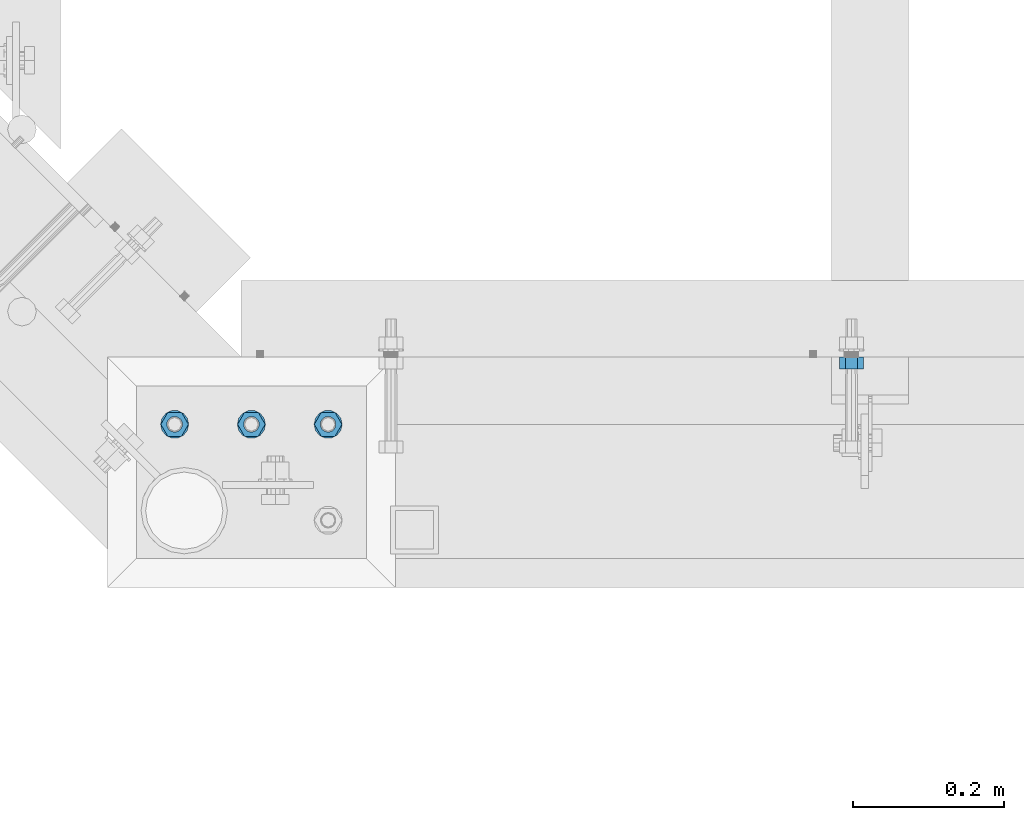
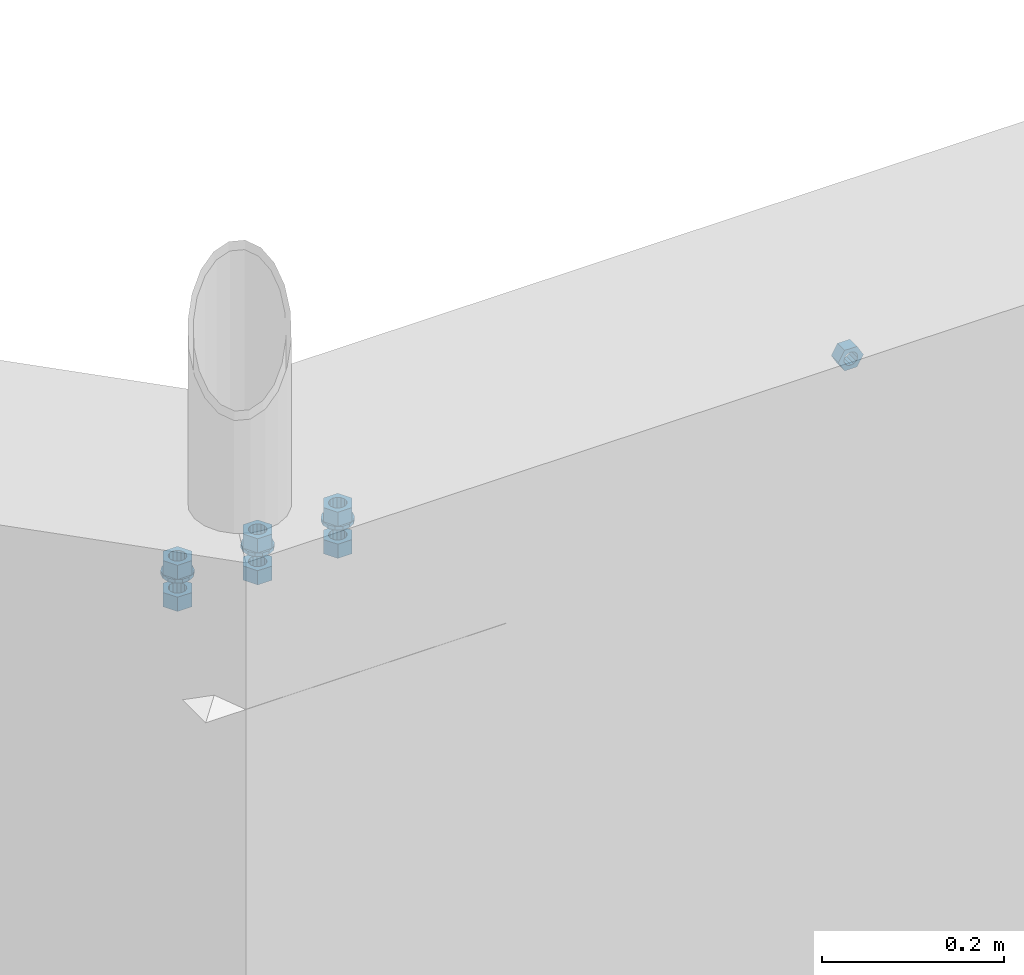
# One storey, part 539 of 975: 10 beams.
"""IFC2X3 building model written with IfcOpenShell, lengths in millimetres."""

from ifc_helpers import new_model, si_unit, frame, origin_with_axes, place, context, subcontext, project, spatial, faceted_brep, material, type_object, element, save


model = new_model("IFC2X3")

# Units and contexts
model_context = context("Model", 3, precision=1e-05, world=origin_with_axes())
body_context = subcontext(model_context, "Body", "Model", "MODEL_VIEW")
ifc_project = project(units=[si_unit("LENGTHUNIT", "METRE", prefix="MILLI"), si_unit("AREAUNIT", "SQUARE_METRE"), si_unit("VOLUMEUNIT", "CUBIC_METRE"), si_unit("MASSUNIT", "GRAM", prefix="KILO"), si_unit("TIMEUNIT", "SECOND"), si_unit("PLANEANGLEUNIT", "RADIAN"), si_unit("SOLIDANGLEUNIT", "STERADIAN"), si_unit("THERMODYNAMICTEMPERATUREUNIT", "DEGREE_CELSIUS"), si_unit("LUMINOUSINTENSITYUNIT", "LUMEN")], contexts=[model_context])

# Site, building, storey
site_placement = place(None, origin_with_axes())
site = spatial("IfcSite", under=ifc_project, at=site_placement, CompositionType="ELEMENT")
building_placement = place(site_placement, origin_with_axes())
building = spatial("IfcBuilding", under=site, at=building_placement, Name="Undefined", CompositionType="ELEMENT")
storey_placement = place(building_placement, origin_with_axes())
storey = spatial("IfcBuildingStorey", under=building, at=storey_placement, Name="Undefined", CompositionType="ELEMENT", Elevation=0.0)

# Beams
ifc_material = material(Name="STEEL/A36")
beam_type_1 = type_object("IfcBeamType", Name="5/8_HEAVY_HEX_NUT", PredefinedType="NOTDEFINED")
beam_1_placement = place(storey_placement, frame((5388.65960907062, 304.799999999999, 3886.2), z_axis=(0.0, 0.0, 1.0), x_axis=(0.0, -1.0, 0.0)))
element("IfcBeam", 1, at=beam_1_placement, inside=storey, type_object=beam_type_1, material=ifc_material, Name="NUT", ObjectType="5/8_HEAVY_HEX_NUT", context=body_context, shape_type="Brep", body=[
    faceted_brep([(-1.09139364212751e-11, -15.8800001144436, -2.72848410531878e-12), (1.45519152283669e-11, -7.94000005722046, -13.7500000000036), (15.8750000000146, -7.94000005722137, -13.7500000000045), (15.8749999999891, -15.8800001144446, -2.72848410531878e-12), (2.91038304567337e-11, 7.94000005722319, -13.7500000000027), (15.8750000000291, 7.94000005722319, -13.7500000000027), (2.18278728425503e-11, 15.8800001144436, 9.09494701772928e-13), (15.8750000000218, 15.8800001144427, 9.09494701772928e-13), (-7.27595761418343e-12, 7.94000005722046, 13.7500000000027), (15.8749999999927, 7.94000005722046, 13.7500000000027), (-2.18278728425503e-11, -7.94000005722228, 13.7500000000009), (15.8749999999782, -7.94000005722319, 13.7500000000009), (-7.27595761418343e-12, 0.0, 8.72999954223724), (0.0, 3.78780484388062, 7.86545780435881), (15.875, 3.78780484387971, 7.86545780435881), (15.8749999999927, -9.09494701772928e-13, 8.72999954223724), (7.27595761418343e-12, 6.82538848405238, 5.44306568481716), (15.8750000000073, 6.82538848405238, 5.44306568481716), (1.09139364212751e-11, 8.51112022706275, 1.94260765157742), (15.8750000000109, 8.51112022706093, 1.94260765157651), (1.45519152283669e-11, 8.51112022706184, -1.94260765157651), (15.8750000000146, 8.51112022706184, -1.94260765157651), (2.18278728425503e-11, 6.8253884840542, -5.44306568481716), (15.8750000000218, 6.82538848405238, -5.44306568481716), (1.81898940354586e-11, 3.78780484388153, -7.86545780435881), (15.8750000000182, 3.78780484388062, -7.86545780435881), (1.81898940354586e-11, 9.09494701772928e-13, -8.72999954223997), (15.8750000000182, 9.09494701772928e-13, -8.72999954223997), (1.09139364212751e-11, -3.78780484387971, -7.86545780436063), (15.8750000000109, -3.78780484388062, -7.86545780436063), (3.63797880709171e-12, -6.82538848405238, -5.44306568481807), (15.8750000000036, -6.82538848405329, -5.44306568481807), (0.0, -8.51112022706184, -1.94260765157833), (15.875, -8.51112022706184, -1.94260765157833), (-7.27595761418343e-12, -8.51112022706184, 1.9426076515756), (15.8749999999927, -8.51112022706275, 1.9426076515756), (-1.09139364212751e-11, -6.82538848405329, 5.44306568481534), (15.8749999999927, -6.8253884840542, 5.44306568481534), (-7.27595761418343e-12, -3.78780484388062, 7.8654578043579), (15.8749999999927, -3.78780484388153, 7.8654578043579)], [[[0, 1, 2, 3]], [[1, 4, 5, 2]], [[4, 6, 7, 5]], [[6, 8, 9, 7]], [[8, 10, 11, 9]], [[10, 0, 3, 11]], [[12, 13, 14, 15]], [[13, 16, 17, 14]], [[16, 18, 19, 17]], [[18, 20, 21, 19]], [[20, 22, 23, 21]], [[22, 24, 25, 23]], [[24, 26, 27, 25]], [[26, 28, 29, 27]], [[28, 30, 31, 29]], [[30, 32, 33, 31]], [[32, 34, 35, 33]], [[34, 36, 37, 35]], [[36, 38, 39, 37]], [[38, 12, 15, 39]], [[5, 7, 9, 11, 3, 2], [17, 19, 21, 23, 25, 27, 29, 31, 33, 35, 37, 39, 15, 14]], [[10, 8, 6, 4, 1, 0], [38, 36, 34, 32, 30, 28, 26, 24, 22, 20, 18, 16, 13, 12]]]),
])
beam_type_2 = type_object("IfcBeamType", Name="3/4_WASHER", PredefinedType="NOTDEFINED")
beam_2_placement = place(storey_placement, frame((4594.22499721142, 215.8999986637, 3960.8125), z_axis=(0.0, 1.0, 0.0), x_axis=(0.0, 0.0, -1.0)))
element("IfcBeam", 2, at=beam_2_placement, inside=storey, type_object=beam_type_2, material=ifc_material, Name="WASHER", ObjectType="3/4_WASHER", context=body_context, shape_type="Brep", body=[
    faceted_brep([(0.0, -18.6499996185303, 0.0), (0.0, -16.8030690426876, -8.09193156902904), (4.76250000000073, -16.8030690426876, -8.09193156902904), (4.76250000000073, -18.6499996185303, 0.0), (0.0, -11.6280845668225, -14.5811568497838), (4.76250000000073, -11.6280845668225, -14.5811568497838), (0.0, -4.15001533340001, -18.1824051902857), (4.76250000000073, -4.15001533340001, -18.1824051902857), (0.0, 4.15001533340001, -18.1824051902857), (4.76250000000073, 4.15001533340001, -18.1824051902857), (0.0, 11.6280845668234, -14.5811568497838), (4.76250000000073, 11.6280845668234, -14.5811568497838), (0.0, 16.8030690426876, -8.09193156902904), (4.76250000000073, 16.8030690426876, -8.09193156902904), (0.0, 18.6499996185303, 0.0), (4.76250000000073, 18.6499996185303, 0.0), (0.0, 16.8030690426876, 8.09193156902904), (4.76250000000073, 16.8030690426876, 8.09193156902904), (0.0, 11.6280845668225, 14.5811568497838), (4.76250000000073, 11.6280845668225, 14.5811568497838), (0.0, 4.15001533340001, 18.1824051902857), (4.76250000000073, 4.15001533340001, 18.1824051902857), (0.0, -4.15001533340001, 18.1824051902857), (4.76250000000073, -4.15001533340001, 18.1824051902857), (0.0, -11.6280845668234, 14.5811568497838), (4.76250000000073, -11.6280845668234, 14.5811568497838), (0.0, -16.8030690426876, 8.09193156902904), (4.76250000000073, -16.8030690426876, 8.09193156902904), (0.0, 0.0, 10.3199996948242), (0.0, 4.47768005528269, 9.29799844179911), (4.76250000000073, 4.47768005528269, 9.29799844179911), (4.76250000000073, 0.0, 10.3199996948242), (0.0, 8.06850066047446, 6.43441456490817), (4.76250000000073, 8.06850066047446, 6.43441456490817), (0.0, 10.0612557561917, 2.29641597052117), (4.76250000000073, 10.0612557561917, 2.29641597052117), (0.0, 10.0612557561917, -2.29641597052117), (4.76250000000073, 10.0612557561917, -2.29641597052117), (0.0, 8.06850066047446, -6.43441456490814), (4.76250000000073, 8.06850066047446, -6.43441456490814), (0.0, 4.47768005528269, -9.29799844179908), (4.76250000000073, 4.47768005528269, -9.29799844179908), (0.0, 0.0, -10.3199996948242), (4.76250000000073, 0.0, -10.3199996948242), (0.0, -4.47768005528269, -9.29799844179911), (4.76250000000073, -4.47768005528269, -9.29799844179911), (0.0, -8.06850066047446, -6.43441456490817), (4.76250000000073, -8.06850066047446, -6.43441456490817), (0.0, -10.0612557561917, -2.29641597052117), (4.76250000000073, -10.0612557561917, -2.29641597052117), (0.0, -10.0612557561917, 2.29641597052117), (4.76250000000073, -10.0612557561917, 2.29641597052117), (0.0, -8.06850066047446, 6.43441456490814), (4.76250000000073, -8.06850066047446, 6.43441456490814), (0.0, -4.47768005528269, 9.29799844179908), (4.76250000000073, -4.47768005528269, 9.29799844179908)], [[[0, 1, 2, 3]], [[1, 4, 5, 2]], [[4, 6, 7, 5]], [[6, 8, 9, 7]], [[8, 10, 11, 9]], [[10, 12, 13, 11]], [[12, 14, 15, 13]], [[14, 16, 17, 15]], [[16, 18, 19, 17]], [[18, 20, 21, 19]], [[20, 22, 23, 21]], [[22, 24, 25, 23]], [[24, 26, 27, 25]], [[26, 0, 3, 27]], [[28, 29, 30, 31]], [[29, 32, 33, 30]], [[32, 34, 35, 33]], [[34, 36, 37, 35]], [[36, 38, 39, 37]], [[38, 40, 41, 39]], [[40, 42, 43, 41]], [[42, 44, 45, 43]], [[44, 46, 47, 45]], [[46, 48, 49, 47]], [[48, 50, 51, 49]], [[50, 52, 53, 51]], [[52, 54, 55, 53]], [[54, 28, 31, 55]], [[5, 7, 9, 11, 13, 15, 17, 19, 21, 23, 25, 27, 3, 2], [33, 35, 37, 39, 41, 43, 45, 47, 49, 51, 53, 55, 31, 30]], [[26, 24, 22, 20, 18, 16, 14, 12, 10, 8, 6, 4, 1, 0], [54, 52, 50, 48, 46, 44, 42, 40, 38, 36, 34, 32, 29, 28]]]),
])
beam_3_placement = place(storey_placement, frame((4492.62500038641, 215.900001391127, 3960.8125), z_axis=(0.0, 1.0, 0.0), x_axis=(0.0, 0.0, -1.0)))
element("IfcBeam", 3, at=beam_3_placement, inside=storey, type_object=beam_type_2, material=ifc_material, Name="WASHER", ObjectType="3/4_WASHER", context=body_context, shape_type="Brep", body=[
    faceted_brep([(0.0, -18.6499996185303, 0.0), (0.0, -16.8030690426876, -8.09193156902904), (4.76250000000073, -16.8030690426876, -8.09193156902904), (4.76250000000073, -18.6499996185303, 0.0), (0.0, -11.6280845668225, -14.5811568497838), (4.76250000000073, -11.6280845668225, -14.5811568497838), (0.0, -4.15001533340001, -18.1824051902857), (4.76250000000073, -4.15001533340001, -18.1824051902857), (0.0, 4.15001533340001, -18.1824051902857), (4.76250000000073, 4.15001533340001, -18.1824051902857), (0.0, 11.6280845668234, -14.5811568497838), (4.76250000000073, 11.6280845668234, -14.5811568497838), (0.0, 16.8030690426876, -8.09193156902904), (4.76250000000073, 16.8030690426876, -8.09193156902904), (0.0, 18.6499996185303, 0.0), (4.76250000000073, 18.6499996185303, 0.0), (0.0, 16.8030690426876, 8.09193156902904), (4.76250000000073, 16.8030690426876, 8.09193156902904), (0.0, 11.6280845668225, 14.5811568497838), (4.76250000000073, 11.6280845668225, 14.5811568497838), (0.0, 4.15001533340001, 18.1824051902857), (4.76250000000073, 4.15001533340001, 18.1824051902857), (0.0, -4.15001533340001, 18.1824051902857), (4.76250000000073, -4.15001533340001, 18.1824051902857), (0.0, -11.6280845668234, 14.5811568497838), (4.76250000000073, -11.6280845668234, 14.5811568497838), (0.0, -16.8030690426876, 8.09193156902904), (4.76250000000073, -16.8030690426876, 8.09193156902904), (0.0, 0.0, 10.3199996948242), (0.0, 4.47768005528269, 9.29799844179911), (4.76250000000073, 4.47768005528269, 9.29799844179911), (4.76250000000073, 0.0, 10.3199996948242), (0.0, 8.06850066047446, 6.43441456490817), (4.76250000000073, 8.06850066047446, 6.43441456490817), (0.0, 10.0612557561917, 2.29641597052117), (4.76250000000073, 10.0612557561917, 2.29641597052117), (0.0, 10.0612557561917, -2.29641597052117), (4.76250000000073, 10.0612557561917, -2.29641597052117), (0.0, 8.06850066047446, -6.43441456490814), (4.76250000000073, 8.06850066047446, -6.43441456490814), (0.0, 4.47768005528269, -9.29799844179908), (4.76250000000073, 4.47768005528269, -9.29799844179908), (0.0, 0.0, -10.3199996948242), (4.76250000000073, 0.0, -10.3199996948242), (0.0, -4.47768005528269, -9.29799844179911), (4.76250000000073, -4.47768005528269, -9.29799844179911), (0.0, -8.06850066047446, -6.43441456490817), (4.76250000000073, -8.06850066047446, -6.43441456490817), (0.0, -10.0612557561917, -2.29641597052117), (4.76250000000073, -10.0612557561917, -2.29641597052117), (0.0, -10.0612557561917, 2.29641597052117), (4.76250000000073, -10.0612557561917, 2.29641597052117), (0.0, -8.06850066047446, 6.43441456490814), (4.76250000000073, -8.06850066047446, 6.43441456490814), (0.0, -4.47768005528269, 9.29799844179908), (4.76250000000073, -4.47768005528269, 9.29799844179908)], [[[0, 1, 2, 3]], [[1, 4, 5, 2]], [[4, 6, 7, 5]], [[6, 8, 9, 7]], [[8, 10, 11, 9]], [[10, 12, 13, 11]], [[12, 14, 15, 13]], [[14, 16, 17, 15]], [[16, 18, 19, 17]], [[18, 20, 21, 19]], [[20, 22, 23, 21]], [[22, 24, 25, 23]], [[24, 26, 27, 25]], [[26, 0, 3, 27]], [[28, 29, 30, 31]], [[29, 32, 33, 30]], [[32, 34, 35, 33]], [[34, 36, 37, 35]], [[36, 38, 39, 37]], [[38, 40, 41, 39]], [[40, 42, 43, 41]], [[42, 44, 45, 43]], [[44, 46, 47, 45]], [[46, 48, 49, 47]], [[48, 50, 51, 49]], [[50, 52, 53, 51]], [[52, 54, 55, 53]], [[54, 28, 31, 55]], [[5, 7, 9, 11, 13, 15, 17, 19, 21, 23, 25, 27, 3, 2], [33, 35, 37, 39, 41, 43, 45, 47, 49, 51, 53, 55, 31, 30]], [[26, 24, 22, 20, 18, 16, 14, 12, 10, 8, 6, 4, 1, 0], [54, 52, 50, 48, 46, 44, 42, 40, 38, 36, 34, 32, 29, 28]]]),
])
beam_4_placement = place(storey_placement, frame((4695.82500038642, 215.9000012037, 3960.8125), z_axis=(0.0, 1.0, 0.0), x_axis=(0.0, 0.0, -1.0)))
element("IfcBeam", 4, at=beam_4_placement, inside=storey, type_object=beam_type_2, material=ifc_material, Name="WASHER", ObjectType="3/4_WASHER", context=body_context, shape_type="Brep", body=[
    faceted_brep([(0.0, -18.6499996185303, 0.0), (0.0, -16.8030690426876, -8.09193156902904), (4.76250000000073, -16.8030690426876, -8.09193156902904), (4.76250000000073, -18.6499996185303, 0.0), (0.0, -11.6280845668225, -14.5811568497838), (4.76250000000073, -11.6280845668225, -14.5811568497838), (0.0, -4.15001533340001, -18.1824051902857), (4.76250000000073, -4.15001533340001, -18.1824051902857), (0.0, 4.15001533340001, -18.1824051902857), (4.76250000000073, 4.15001533340001, -18.1824051902857), (0.0, 11.6280845668234, -14.5811568497838), (4.76250000000073, 11.6280845668234, -14.5811568497838), (0.0, 16.8030690426876, -8.09193156902904), (4.76250000000073, 16.8030690426876, -8.09193156902904), (0.0, 18.6499996185303, 0.0), (4.76250000000073, 18.6499996185303, 0.0), (0.0, 16.8030690426876, 8.09193156902904), (4.76250000000073, 16.8030690426876, 8.09193156902904), (0.0, 11.6280845668225, 14.5811568497838), (4.76250000000073, 11.6280845668225, 14.5811568497838), (0.0, 4.15001533340001, 18.1824051902857), (4.76250000000073, 4.15001533340001, 18.1824051902857), (0.0, -4.15001533340001, 18.1824051902857), (4.76250000000073, -4.15001533340001, 18.1824051902857), (0.0, -11.6280845668234, 14.5811568497838), (4.76250000000073, -11.6280845668234, 14.5811568497838), (0.0, -16.8030690426876, 8.09193156902904), (4.76250000000073, -16.8030690426876, 8.09193156902904), (0.0, 0.0, 10.3199996948242), (0.0, 4.47768005528269, 9.29799844179911), (4.76250000000073, 4.47768005528269, 9.29799844179911), (4.76250000000073, 0.0, 10.3199996948242), (0.0, 8.06850066047446, 6.43441456490817), (4.76250000000073, 8.06850066047446, 6.43441456490817), (0.0, 10.0612557561917, 2.29641597052117), (4.76250000000073, 10.0612557561917, 2.29641597052117), (0.0, 10.0612557561917, -2.29641597052117), (4.76250000000073, 10.0612557561917, -2.29641597052117), (0.0, 8.06850066047446, -6.43441456490814), (4.76250000000073, 8.06850066047446, -6.43441456490814), (0.0, 4.47768005528269, -9.29799844179908), (4.76250000000073, 4.47768005528269, -9.29799844179908), (0.0, 0.0, -10.3199996948242), (4.76250000000073, 0.0, -10.3199996948242), (0.0, -4.47768005528269, -9.29799844179911), (4.76250000000073, -4.47768005528269, -9.29799844179911), (0.0, -8.06850066047446, -6.43441456490817), (4.76250000000073, -8.06850066047446, -6.43441456490817), (0.0, -10.0612557561917, -2.29641597052117), (4.76250000000073, -10.0612557561917, -2.29641597052117), (0.0, -10.0612557561917, 2.29641597052117), (4.76250000000073, -10.0612557561917, 2.29641597052117), (0.0, -8.06850066047446, 6.43441456490814), (4.76250000000073, -8.06850066047446, 6.43441456490814), (0.0, -4.47768005528269, 9.29799844179908), (4.76250000000073, -4.47768005528269, 9.29799844179908)], [[[0, 1, 2, 3]], [[1, 4, 5, 2]], [[4, 6, 7, 5]], [[6, 8, 9, 7]], [[8, 10, 11, 9]], [[10, 12, 13, 11]], [[12, 14, 15, 13]], [[14, 16, 17, 15]], [[16, 18, 19, 17]], [[18, 20, 21, 19]], [[20, 22, 23, 21]], [[22, 24, 25, 23]], [[24, 26, 27, 25]], [[26, 0, 3, 27]], [[28, 29, 30, 31]], [[29, 32, 33, 30]], [[32, 34, 35, 33]], [[34, 36, 37, 35]], [[36, 38, 39, 37]], [[38, 40, 41, 39]], [[40, 42, 43, 41]], [[42, 44, 45, 43]], [[44, 46, 47, 45]], [[46, 48, 49, 47]], [[48, 50, 51, 49]], [[50, 52, 53, 51]], [[52, 54, 55, 53]], [[54, 28, 31, 55]], [[5, 7, 9, 11, 13, 15, 17, 19, 21, 23, 25, 27, 3, 2], [33, 35, 37, 39, 41, 43, 45, 47, 49, 51, 53, 55, 31, 30]], [[26, 24, 22, 20, 18, 16, 14, 12, 10, 8, 6, 4, 1, 0], [54, 52, 50, 48, 46, 44, 42, 40, 38, 36, 34, 32, 29, 28]]]),
])
beam_type_3 = type_object("IfcBeamType", Name="3/4_HEAVY_HEX_NUT", PredefinedType="NOTDEFINED")
beam_5_placement = place(storey_placement, frame((4594.22499721142, 215.8999986637, 3979.8625), z_axis=(0.0, 1.0, 0.0), x_axis=(0.0, 0.0, -1.0)))
element("IfcBeam", 5, at=beam_5_placement, inside=storey, type_object=beam_type_3, material=ifc_material, Name="NUT", ObjectType="3/4_HEAVY_HEX_NUT", context=body_context, shape_type="Brep", body=[
    faceted_brep([(0.0, -18.2600002288818, 0.0), (0.0, -9.13000011444092, -15.8100004196167), (19.0499999999993, -9.13000011444092, -15.8100004196167), (19.0499999999993, -18.2600002288818, 0.0), (0.0, 9.13000011444092, -15.8100004196167), (19.0499999999993, 9.13000011444092, -15.8100004196167), (0.0, 18.2600002288818, 0.0), (19.0499999999993, 18.2600002288818, 0.0), (0.0, 9.13000011444092, 15.8100004196167), (19.0499999999993, 9.13000011444092, 15.8100004196167), (0.0, -9.13000011444092, 15.8100004196167), (19.0499999999993, -9.13000011444092, 15.8100004196167), (0.0, 0.0, 10.3199996948242), (0.0, 4.47768005528269, 9.29799844179911), (19.0499999999993, 4.47768005528269, 9.29799844179911), (19.0499999999993, 0.0, 10.3199996948242), (0.0, 8.06850066047446, 6.43441456490817), (19.0499999999993, 8.06850066047446, 6.43441456490817), (0.0, 10.0612557561917, 2.29641597052117), (19.0499999999993, 10.0612557561917, 2.29641597052117), (0.0, 10.0612557561917, -2.29641597052117), (19.0499999999993, 10.0612557561917, -2.29641597052117), (0.0, 8.06850066047446, -6.43441456490814), (19.0499999999993, 8.06850066047446, -6.43441456490814), (0.0, 4.47768005528269, -9.29799844179908), (19.0499999999993, 4.47768005528269, -9.29799844179908), (0.0, 0.0, -10.3199996948242), (19.0499999999993, 0.0, -10.3199996948242), (0.0, -4.47768005528269, -9.29799844179911), (19.0499999999993, -4.47768005528269, -9.29799844179911), (0.0, -8.06850066047446, -6.43441456490817), (19.0499999999993, -8.06850066047446, -6.43441456490817), (0.0, -10.0612557561917, -2.29641597052117), (19.0499999999993, -10.0612557561917, -2.29641597052117), (0.0, -10.0612557561917, 2.29641597052117), (19.0499999999993, -10.0612557561917, 2.29641597052117), (0.0, -8.06850066047446, 6.43441456490814), (19.0499999999993, -8.06850066047446, 6.43441456490814), (0.0, -4.47768005528269, 9.29799844179908), (19.0499999999993, -4.47768005528269, 9.29799844179908)], [[[0, 1, 2, 3]], [[1, 4, 5, 2]], [[4, 6, 7, 5]], [[6, 8, 9, 7]], [[8, 10, 11, 9]], [[10, 0, 3, 11]], [[12, 13, 14, 15]], [[13, 16, 17, 14]], [[16, 18, 19, 17]], [[18, 20, 21, 19]], [[20, 22, 23, 21]], [[22, 24, 25, 23]], [[24, 26, 27, 25]], [[26, 28, 29, 27]], [[28, 30, 31, 29]], [[30, 32, 33, 31]], [[32, 34, 35, 33]], [[34, 36, 37, 35]], [[36, 38, 39, 37]], [[38, 12, 15, 39]], [[5, 7, 9, 11, 3, 2], [17, 19, 21, 23, 25, 27, 29, 31, 33, 35, 37, 39, 15, 14]], [[10, 8, 6, 4, 1, 0], [38, 36, 34, 32, 30, 28, 26, 24, 22, 20, 18, 16, 13, 12]]]),
])
beam_6_placement = place(storey_placement, frame((4594.22499556038, 215.899995817023, 3937.0), z_axis=(0.0, 1.0, 0.0), x_axis=(0.0, 0.0, -1.0)))
element("IfcBeam", 6, at=beam_6_placement, inside=storey, type_object=beam_type_3, material=ifc_material, Name="NUT", ObjectType="3/4_HEAVY_HEX_NUT", context=body_context, shape_type="Brep", body=[
    faceted_brep([(0.0, -18.2600002288818, 0.0), (0.0, -9.13000011444092, -15.8100004196167), (19.0499999999993, -9.13000011444092, -15.8100004196167), (19.0499999999993, -18.2600002288818, 0.0), (0.0, 9.13000011444092, -15.8100004196167), (19.0499999999993, 9.13000011444092, -15.8100004196167), (0.0, 18.2600002288818, 0.0), (19.0499999999993, 18.2600002288818, 0.0), (0.0, 9.13000011444092, 15.8100004196167), (19.0499999999993, 9.13000011444092, 15.8100004196167), (0.0, -9.13000011444092, 15.8100004196167), (19.0499999999993, -9.13000011444092, 15.8100004196167), (0.0, 0.0, 10.3199996948242), (0.0, 4.47768005528269, 9.29799844179911), (19.0499999999993, 4.47768005528269, 9.29799844179911), (19.0499999999993, 0.0, 10.3199996948242), (0.0, 8.06850066047446, 6.43441456490817), (19.0499999999993, 8.06850066047446, 6.43441456490817), (0.0, 10.0612557561917, 2.29641597052117), (19.0499999999993, 10.0612557561917, 2.29641597052117), (0.0, 10.0612557561917, -2.29641597052117), (19.0499999999993, 10.0612557561917, -2.29641597052117), (0.0, 8.06850066047446, -6.43441456490814), (19.0499999999993, 8.06850066047446, -6.43441456490814), (0.0, 4.47768005528269, -9.29799844179908), (19.0499999999993, 4.47768005528269, -9.29799844179908), (0.0, 0.0, -10.3199996948242), (19.0499999999993, 0.0, -10.3199996948242), (0.0, -4.47768005528269, -9.29799844179911), (19.0499999999993, -4.47768005528269, -9.29799844179911), (0.0, -8.06850066047446, -6.43441456490817), (19.0499999999993, -8.06850066047446, -6.43441456490817), (0.0, -10.0612557561917, -2.29641597052117), (19.0499999999993, -10.0612557561917, -2.29641597052117), (0.0, -10.0612557561917, 2.29641597052117), (19.0499999999993, -10.0612557561917, 2.29641597052117), (0.0, -8.06850066047446, 6.43441456490814), (19.0499999999993, -8.06850066047446, 6.43441456490814), (0.0, -4.47768005528269, 9.29799844179908), (19.0499999999993, -4.47768005528269, 9.29799844179908)], [[[0, 1, 2, 3]], [[1, 4, 5, 2]], [[4, 6, 7, 5]], [[6, 8, 9, 7]], [[8, 10, 11, 9]], [[10, 0, 3, 11]], [[12, 13, 14, 15]], [[13, 16, 17, 14]], [[16, 18, 19, 17]], [[18, 20, 21, 19]], [[20, 22, 23, 21]], [[22, 24, 25, 23]], [[24, 26, 27, 25]], [[26, 28, 29, 27]], [[28, 30, 31, 29]], [[30, 32, 33, 31]], [[32, 34, 35, 33]], [[34, 36, 37, 35]], [[36, 38, 39, 37]], [[38, 12, 15, 39]], [[5, 7, 9, 11, 3, 2], [17, 19, 21, 23, 25, 27, 29, 31, 33, 35, 37, 39, 15, 14]], [[10, 8, 6, 4, 1, 0], [38, 36, 34, 32, 30, 28, 26, 24, 22, 20, 18, 16, 13, 12]]]),
])
beam_7_placement = place(storey_placement, frame((4492.62500038641, 215.900001391127, 3979.8625), z_axis=(0.0, 1.0, 0.0), x_axis=(0.0, 0.0, -1.0)))
element("IfcBeam", 7, at=beam_7_placement, inside=storey, type_object=beam_type_3, material=ifc_material, Name="NUT", ObjectType="3/4_HEAVY_HEX_NUT", context=body_context, shape_type="Brep", body=[
    faceted_brep([(0.0, -18.2600002288818, 0.0), (0.0, -9.13000011444092, -15.8100004196167), (19.0499999999993, -9.13000011444092, -15.8100004196167), (19.0499999999993, -18.2600002288818, 0.0), (0.0, 9.13000011444092, -15.8100004196167), (19.0499999999993, 9.13000011444092, -15.8100004196167), (0.0, 18.2600002288818, 0.0), (19.0499999999993, 18.2600002288818, 0.0), (0.0, 9.13000011444092, 15.8100004196167), (19.0499999999993, 9.13000011444092, 15.8100004196167), (0.0, -9.13000011444092, 15.8100004196167), (19.0499999999993, -9.13000011444092, 15.8100004196167), (0.0, 0.0, 10.3199996948242), (0.0, 4.47768005528269, 9.29799844179911), (19.0499999999993, 4.47768005528269, 9.29799844179911), (19.0499999999993, 0.0, 10.3199996948242), (0.0, 8.06850066047446, 6.43441456490817), (19.0499999999993, 8.06850066047446, 6.43441456490817), (0.0, 10.0612557561917, 2.29641597052117), (19.0499999999993, 10.0612557561917, 2.29641597052117), (0.0, 10.0612557561917, -2.29641597052117), (19.0499999999993, 10.0612557561917, -2.29641597052117), (0.0, 8.06850066047446, -6.43441456490814), (19.0499999999993, 8.06850066047446, -6.43441456490814), (0.0, 4.47768005528269, -9.29799844179908), (19.0499999999993, 4.47768005528269, -9.29799844179908), (0.0, 0.0, -10.3199996948242), (19.0499999999993, 0.0, -10.3199996948242), (0.0, -4.47768005528269, -9.29799844179911), (19.0499999999993, -4.47768005528269, -9.29799844179911), (0.0, -8.06850066047446, -6.43441456490817), (19.0499999999993, -8.06850066047446, -6.43441456490817), (0.0, -10.0612557561917, -2.29641597052117), (19.0499999999993, -10.0612557561917, -2.29641597052117), (0.0, -10.0612557561917, 2.29641597052117), (19.0499999999993, -10.0612557561917, 2.29641597052117), (0.0, -8.06850066047446, 6.43441456490814), (19.0499999999993, -8.06850066047446, 6.43441456490814), (0.0, -4.47768005528269, 9.29799844179908), (19.0499999999993, -4.47768005528269, 9.29799844179908)], [[[0, 1, 2, 3]], [[1, 4, 5, 2]], [[4, 6, 7, 5]], [[6, 8, 9, 7]], [[8, 10, 11, 9]], [[10, 0, 3, 11]], [[12, 13, 14, 15]], [[13, 16, 17, 14]], [[16, 18, 19, 17]], [[18, 20, 21, 19]], [[20, 22, 23, 21]], [[22, 24, 25, 23]], [[24, 26, 27, 25]], [[26, 28, 29, 27]], [[28, 30, 31, 29]], [[30, 32, 33, 31]], [[32, 34, 35, 33]], [[34, 36, 37, 35]], [[36, 38, 39, 37]], [[38, 12, 15, 39]], [[5, 7, 9, 11, 3, 2], [17, 19, 21, 23, 25, 27, 29, 31, 33, 35, 37, 39, 15, 14]], [[10, 8, 6, 4, 1, 0], [38, 36, 34, 32, 30, 28, 26, 24, 22, 20, 18, 16, 13, 12]]]),
])
beam_8_placement = place(storey_placement, frame((4695.82500038642, 215.9000012037, 3979.8625), z_axis=(0.0, 1.0, 0.0), x_axis=(0.0, 0.0, -1.0)))
element("IfcBeam", 8, at=beam_8_placement, inside=storey, type_object=beam_type_3, material=ifc_material, Name="NUT", ObjectType="3/4_HEAVY_HEX_NUT", context=body_context, shape_type="Brep", body=[
    faceted_brep([(0.0, -18.2600002288818, 0.0), (0.0, -9.13000011444092, -15.8100004196167), (19.0499999999993, -9.13000011444092, -15.8100004196167), (19.0499999999993, -18.2600002288818, 0.0), (0.0, 9.13000011444092, -15.8100004196167), (19.0499999999993, 9.13000011444092, -15.8100004196167), (0.0, 18.2600002288818, 0.0), (19.0499999999993, 18.2600002288818, 0.0), (0.0, 9.13000011444092, 15.8100004196167), (19.0499999999993, 9.13000011444092, 15.8100004196167), (0.0, -9.13000011444092, 15.8100004196167), (19.0499999999993, -9.13000011444092, 15.8100004196167), (0.0, 0.0, 10.3199996948242), (0.0, 4.47768005528269, 9.29799844179911), (19.0499999999993, 4.47768005528269, 9.29799844179911), (19.0499999999993, 0.0, 10.3199996948242), (0.0, 8.06850066047446, 6.43441456490817), (19.0499999999993, 8.06850066047446, 6.43441456490817), (0.0, 10.0612557561917, 2.29641597052117), (19.0499999999993, 10.0612557561917, 2.29641597052117), (0.0, 10.0612557561917, -2.29641597052117), (19.0499999999993, 10.0612557561917, -2.29641597052117), (0.0, 8.06850066047446, -6.43441456490814), (19.0499999999993, 8.06850066047446, -6.43441456490814), (0.0, 4.47768005528269, -9.29799844179908), (19.0499999999993, 4.47768005528269, -9.29799844179908), (0.0, 0.0, -10.3199996948242), (19.0499999999993, 0.0, -10.3199996948242), (0.0, -4.47768005528269, -9.29799844179911), (19.0499999999993, -4.47768005528269, -9.29799844179911), (0.0, -8.06850066047446, -6.43441456490817), (19.0499999999993, -8.06850066047446, -6.43441456490817), (0.0, -10.0612557561917, -2.29641597052117), (19.0499999999993, -10.0612557561917, -2.29641597052117), (0.0, -10.0612557561917, 2.29641597052117), (19.0499999999993, -10.0612557561917, 2.29641597052117), (0.0, -8.06850066047446, 6.43441456490814), (19.0499999999993, -8.06850066047446, 6.43441456490814), (0.0, -4.47768005528269, 9.29799844179908), (19.0499999999993, -4.47768005528269, 9.29799844179908)], [[[0, 1, 2, 3]], [[1, 4, 5, 2]], [[4, 6, 7, 5]], [[6, 8, 9, 7]], [[8, 10, 11, 9]], [[10, 0, 3, 11]], [[12, 13, 14, 15]], [[13, 16, 17, 14]], [[16, 18, 19, 17]], [[18, 20, 21, 19]], [[20, 22, 23, 21]], [[22, 24, 25, 23]], [[24, 26, 27, 25]], [[26, 28, 29, 27]], [[28, 30, 31, 29]], [[30, 32, 33, 31]], [[32, 34, 35, 33]], [[34, 36, 37, 35]], [[36, 38, 39, 37]], [[38, 12, 15, 39]], [[5, 7, 9, 11, 3, 2], [17, 19, 21, 23, 25, 27, 29, 31, 33, 35, 37, 39, 15, 14]], [[10, 8, 6, 4, 1, 0], [38, 36, 34, 32, 30, 28, 26, 24, 22, 20, 18, 16, 13, 12]]]),
])
beam_9_placement = place(storey_placement, frame((4492.62500038641, 215.900001391127, 3937.0), z_axis=(0.0, 1.0, 0.0), x_axis=(0.0, 0.0, -1.0)))
element("IfcBeam", 9, at=beam_9_placement, inside=storey, type_object=beam_type_3, material=ifc_material, Name="NUT", ObjectType="3/4_HEAVY_HEX_NUT", context=body_context, shape_type="Brep", body=[
    faceted_brep([(0.0, -18.2600002288818, 0.0), (0.0, -9.13000011444092, -15.8100004196167), (19.0499999999993, -9.13000011444092, -15.8100004196167), (19.0499999999993, -18.2600002288818, 0.0), (0.0, 9.13000011444092, -15.8100004196167), (19.0499999999993, 9.13000011444092, -15.8100004196167), (0.0, 18.2600002288818, 0.0), (19.0499999999993, 18.2600002288818, 0.0), (0.0, 9.13000011444092, 15.8100004196167), (19.0499999999993, 9.13000011444092, 15.8100004196167), (0.0, -9.13000011444092, 15.8100004196167), (19.0499999999993, -9.13000011444092, 15.8100004196167), (0.0, 0.0, 10.3199996948242), (0.0, 4.47768005528269, 9.29799844179911), (19.0499999999993, 4.47768005528269, 9.29799844179911), (19.0499999999993, 0.0, 10.3199996948242), (0.0, 8.06850066047446, 6.43441456490817), (19.0499999999993, 8.06850066047446, 6.43441456490817), (0.0, 10.0612557561917, 2.29641597052117), (19.0499999999993, 10.0612557561917, 2.29641597052117), (0.0, 10.0612557561917, -2.29641597052117), (19.0499999999993, 10.0612557561917, -2.29641597052117), (0.0, 8.06850066047446, -6.43441456490814), (19.0499999999993, 8.06850066047446, -6.43441456490814), (0.0, 4.47768005528269, -9.29799844179908), (19.0499999999993, 4.47768005528269, -9.29799844179908), (0.0, 0.0, -10.3199996948242), (19.0499999999993, 0.0, -10.3199996948242), (0.0, -4.47768005528269, -9.29799844179911), (19.0499999999993, -4.47768005528269, -9.29799844179911), (0.0, -8.06850066047446, -6.43441456490817), (19.0499999999993, -8.06850066047446, -6.43441456490817), (0.0, -10.0612557561917, -2.29641597052117), (19.0499999999993, -10.0612557561917, -2.29641597052117), (0.0, -10.0612557561917, 2.29641597052117), (19.0499999999993, -10.0612557561917, 2.29641597052117), (0.0, -8.06850066047446, 6.43441456490814), (19.0499999999993, -8.06850066047446, 6.43441456490814), (0.0, -4.47768005528269, 9.29799844179908), (19.0499999999993, -4.47768005528269, 9.29799844179908)], [[[0, 1, 2, 3]], [[1, 4, 5, 2]], [[4, 6, 7, 5]], [[6, 8, 9, 7]], [[8, 10, 11, 9]], [[10, 0, 3, 11]], [[12, 13, 14, 15]], [[13, 16, 17, 14]], [[16, 18, 19, 17]], [[18, 20, 21, 19]], [[20, 22, 23, 21]], [[22, 24, 25, 23]], [[24, 26, 27, 25]], [[26, 28, 29, 27]], [[28, 30, 31, 29]], [[30, 32, 33, 31]], [[32, 34, 35, 33]], [[34, 36, 37, 35]], [[36, 38, 39, 37]], [[38, 12, 15, 39]], [[5, 7, 9, 11, 3, 2], [17, 19, 21, 23, 25, 27, 29, 31, 33, 35, 37, 39, 15, 14]], [[10, 8, 6, 4, 1, 0], [38, 36, 34, 32, 30, 28, 26, 24, 22, 20, 18, 16, 13, 12]]]),
])
beam_10_placement = place(storey_placement, frame((4695.82500038642, 215.9000012037, 3937.0), z_axis=(0.0, 1.0, 0.0), x_axis=(0.0, 0.0, -1.0)))
element("IfcBeam", 10, at=beam_10_placement, inside=storey, type_object=beam_type_3, material=ifc_material, Name="NUT", ObjectType="3/4_HEAVY_HEX_NUT", context=body_context, shape_type="Brep", body=[
    faceted_brep([(0.0, -18.2600002288818, 0.0), (0.0, -9.13000011444092, -15.8100004196167), (19.0499999999993, -9.13000011444092, -15.8100004196167), (19.0499999999993, -18.2600002288818, 0.0), (0.0, 9.13000011444092, -15.8100004196167), (19.0499999999993, 9.13000011444092, -15.8100004196167), (0.0, 18.2600002288818, 0.0), (19.0499999999993, 18.2600002288818, 0.0), (0.0, 9.13000011444092, 15.8100004196167), (19.0499999999993, 9.13000011444092, 15.8100004196167), (0.0, -9.13000011444092, 15.8100004196167), (19.0499999999993, -9.13000011444092, 15.8100004196167), (0.0, 0.0, 10.3199996948242), (0.0, 4.47768005528269, 9.29799844179911), (19.0499999999993, 4.47768005528269, 9.29799844179911), (19.0499999999993, 0.0, 10.3199996948242), (0.0, 8.06850066047446, 6.43441456490817), (19.0499999999993, 8.06850066047446, 6.43441456490817), (0.0, 10.0612557561917, 2.29641597052117), (19.0499999999993, 10.0612557561917, 2.29641597052117), (0.0, 10.0612557561917, -2.29641597052117), (19.0499999999993, 10.0612557561917, -2.29641597052117), (0.0, 8.06850066047446, -6.43441456490814), (19.0499999999993, 8.06850066047446, -6.43441456490814), (0.0, 4.47768005528269, -9.29799844179908), (19.0499999999993, 4.47768005528269, -9.29799844179908), (0.0, 0.0, -10.3199996948242), (19.0499999999993, 0.0, -10.3199996948242), (0.0, -4.47768005528269, -9.29799844179911), (19.0499999999993, -4.47768005528269, -9.29799844179911), (0.0, -8.06850066047446, -6.43441456490817), (19.0499999999993, -8.06850066047446, -6.43441456490817), (0.0, -10.0612557561917, -2.29641597052117), (19.0499999999993, -10.0612557561917, -2.29641597052117), (0.0, -10.0612557561917, 2.29641597052117), (19.0499999999993, -10.0612557561917, 2.29641597052117), (0.0, -8.06850066047446, 6.43441456490814), (19.0499999999993, -8.06850066047446, 6.43441456490814), (0.0, -4.47768005528269, 9.29799844179908), (19.0499999999993, -4.47768005528269, 9.29799844179908)], [[[0, 1, 2, 3]], [[1, 4, 5, 2]], [[4, 6, 7, 5]], [[6, 8, 9, 7]], [[8, 10, 11, 9]], [[10, 0, 3, 11]], [[12, 13, 14, 15]], [[13, 16, 17, 14]], [[16, 18, 19, 17]], [[18, 20, 21, 19]], [[20, 22, 23, 21]], [[22, 24, 25, 23]], [[24, 26, 27, 25]], [[26, 28, 29, 27]], [[28, 30, 31, 29]], [[30, 32, 33, 31]], [[32, 34, 35, 33]], [[34, 36, 37, 35]], [[36, 38, 39, 37]], [[38, 12, 15, 39]], [[5, 7, 9, 11, 3, 2], [17, 19, 21, 23, 25, 27, 29, 31, 33, 35, 37, 39, 15, 14]], [[10, 8, 6, 4, 1, 0], [38, 36, 34, 32, 30, 28, 26, 24, 22, 20, 18, 16, 13, 12]]]),
])

save(model, "model.ifc")
